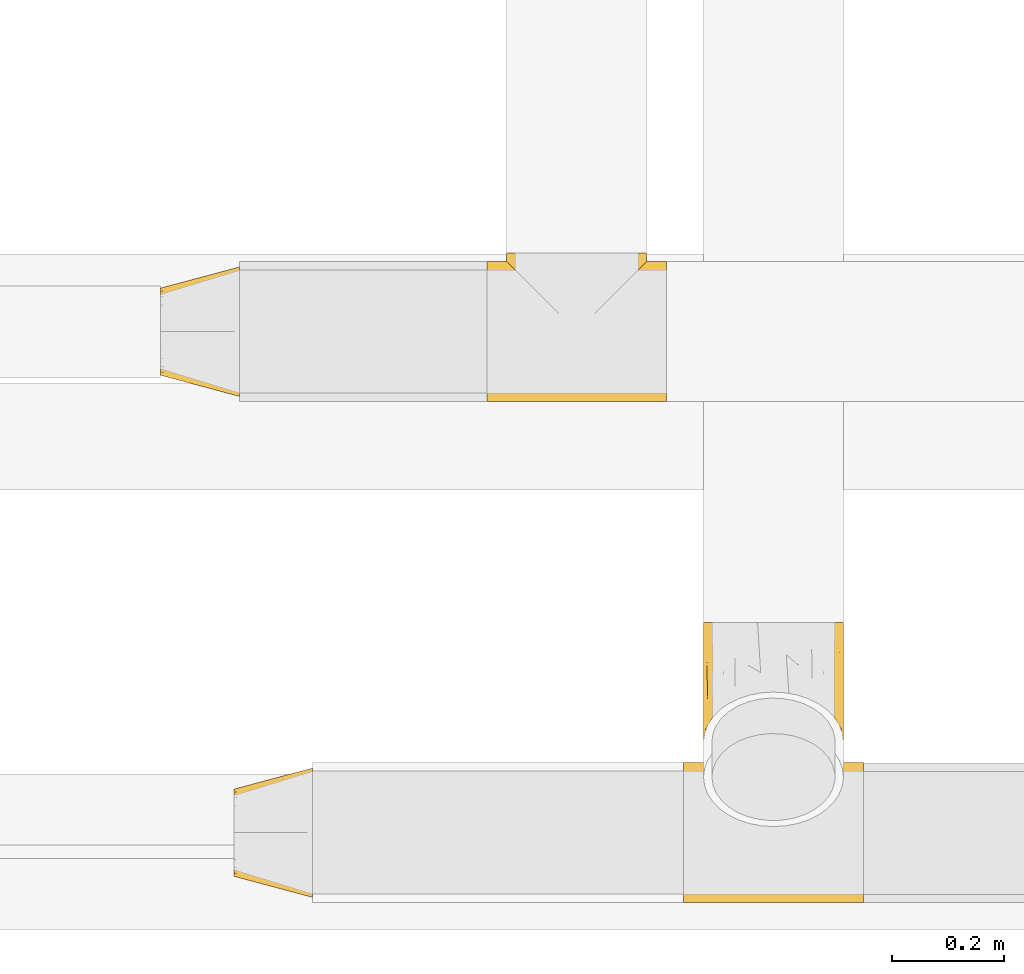
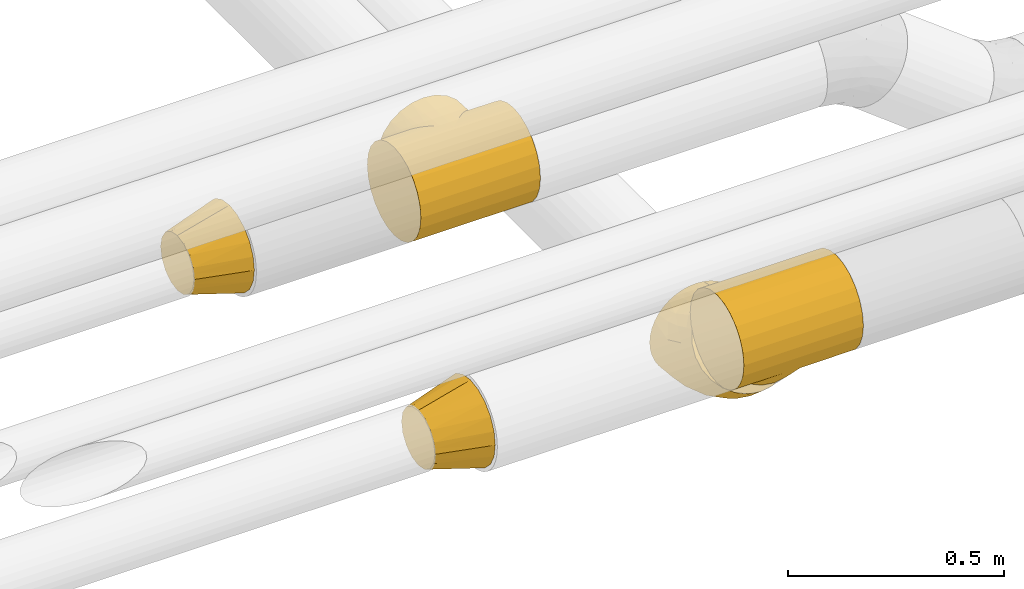
# One storey, part 139 of 827: 5 coverings.
"""IFC2X3 building model written with IfcOpenShell, lengths in millimetres."""

from ifc_helpers import new_model, entity, si_unit, converted_unit, derived_unit, direction, frame, origin, place, context, subcontext, project, spatial, faceted_brep, element, save


model = new_model("IFC2X3")

# Units and contexts
model_context = context("Model", 3, precision=0.01, world=origin(), true_north=direction((6.12303176911189e-17, 1.0)))
body_context = subcontext(model_context, "Body", "Model", "MODEL_VIEW")
ifc_project = project(units=[si_unit("LENGTHUNIT", "METRE", prefix="MILLI"), si_unit("AREAUNIT", "SQUARE_METRE"), si_unit("VOLUMEUNIT", "CUBIC_METRE"), converted_unit("PLANEANGLEUNIT", "DEGREE", entity("IfcRatioMeasure", 0.0174532925199433), si_unit("PLANEANGLEUNIT", "RADIAN"), dimensions=[0, 0, 0, 0, 0, 0, 0]), si_unit("MASSUNIT", "GRAM", prefix="KILO"), derived_unit("MASSDENSITYUNIT", [(si_unit("MASSUNIT", "GRAM", prefix="KILO"), 1), (si_unit("LENGTHUNIT", "METRE"), -3)]), derived_unit("MOMENTOFINERTIAUNIT", [(si_unit("LENGTHUNIT", "METRE"), 4)]), si_unit("TIMEUNIT", "SECOND"), si_unit("FREQUENCYUNIT", "HERTZ"), si_unit("THERMODYNAMICTEMPERATUREUNIT", "DEGREE_CELSIUS"), derived_unit("THERMALTRANSMITTANCEUNIT", [(si_unit("MASSUNIT", "GRAM", prefix="KILO"), 1), (si_unit("THERMODYNAMICTEMPERATUREUNIT", "KELVIN"), -1), (si_unit("TIMEUNIT", "SECOND"), -3)]), derived_unit("VOLUMETRICFLOWRATEUNIT", [(si_unit("LENGTHUNIT", "METRE"), 3), (si_unit("TIMEUNIT", "SECOND"), -1)]), derived_unit("MASSFLOWRATEUNIT", [(si_unit("MASSUNIT", "GRAM", prefix="KILO"), 1), (si_unit("TIMEUNIT", "SECOND"), -1)]), derived_unit("ROTATIONALFREQUENCYUNIT", [(si_unit("TIMEUNIT", "SECOND"), -1)]), si_unit("ELECTRICCURRENTUNIT", "AMPERE"), si_unit("ELECTRICVOLTAGEUNIT", "VOLT"), si_unit("POWERUNIT", "WATT"), si_unit("FORCEUNIT", "NEWTON", prefix="KILO"), si_unit("ILLUMINANCEUNIT", "LUX"), si_unit("LUMINOUSFLUXUNIT", "LUMEN"), si_unit("LUMINOUSINTENSITYUNIT", "CANDELA"), derived_unit("USERDEFINED", [(si_unit("MASSUNIT", "GRAM", prefix="KILO"), -1), (si_unit("LENGTHUNIT", "METRE"), -2), (si_unit("TIMEUNIT", "SECOND"), 3), (si_unit("LUMINOUSFLUXUNIT", "LUMEN"), 1)]), derived_unit("LINEARVELOCITYUNIT", [(si_unit("LENGTHUNIT", "METRE"), 1), (si_unit("TIMEUNIT", "SECOND"), -1)]), si_unit("PRESSUREUNIT", "PASCAL"), derived_unit("USERDEFINED", [(si_unit("LENGTHUNIT", "METRE"), -2), (si_unit("MASSUNIT", "GRAM", prefix="KILO"), 1), (si_unit("TIMEUNIT", "SECOND"), -2)]), derived_unit("LINEARFORCEUNIT", [(si_unit("MASSUNIT", "GRAM", prefix="KILO"), 1), (si_unit("LENGTHUNIT", "METRE"), 1), (si_unit("TIMEUNIT", "SECOND"), -2), (si_unit("LENGTHUNIT", "METRE"), -1)]), derived_unit("PLANARFORCEUNIT", [(si_unit("MASSUNIT", "GRAM", prefix="KILO"), 1), (si_unit("LENGTHUNIT", "METRE"), 1), (si_unit("TIMEUNIT", "SECOND"), -2), (si_unit("LENGTHUNIT", "METRE"), -2)])], contexts=[model_context])

# Site, building, storey
site_placement = place(None, origin())
site = spatial("IfcSite", under=ifc_project, at=site_placement, CompositionType="ELEMENT")
building_placement = place(site_placement, origin())
building = spatial("IfcBuilding", under=site, at=building_placement, CompositionType="ELEMENT")
storey_placement = place(building_placement, frame((0.0, 0.0, 28200.0)))
storey = spatial("IfcBuildingStorey", under=building, at=storey_placement, Name="08", CompositionType="ELEMENT", Elevation=28200.0)

# Coverings
covering_1_placement = place(storey_placement, frame((30920.0, 7140.11, 2673.9)))
element("IfcCovering", 1, at=covering_1_placement, inside=storey, Name=":ADSK_", ObjectType=":ADSK_", PredefinedType="INSULATION", context=body_context, shape_type="Brep", body=[
    faceted_brep([(182.35, 148.44, 248.58), (320.01, 126.1, 250.6), (320.01, 158.32, 246.35), (320.01, 188.35, 233.92), (235.54, 201.62, 225.07), (225.46, 191.55, 232.0), (320.01, 214.13, 214.13), (215.03, 181.12, 237.78), (171.2, 137.29, 250.09), (160.01, 126.1, 250.6), (148.81, 137.29, 250.1), (0.01, 126.1, 250.6), (204.32, 170.41, 242.44), (193.41, 159.5, 246.03), (320.0, 233.92, 188.35), (262.45, 228.54, 196.85), (320.0, 246.35, 158.32), (275.9, 241.99, 171.57), (320.0, 240.13, 173.33), (283.5, 249.59, 141.87), (320.0, 250.6, 126.1), (284.5, 250.6, 126.1), (36.51, 249.59, 141.88), (35.5, 250.6, 126.1), (0.0, 250.6, 126.1), (320.0, 248.47, 142.21), (269.77, 235.86, 184.84), (280.57, 246.66, 157.16), (254.18, 220.27, 207.53), (245.15, 211.24, 216.93), (320.0, 248.47, 109.98), (0.0, 248.47, 109.99), (274.7, 240.79, 77.67), (320.0, 240.13, 78.86), (320.0, 233.92, 63.85), (320.0, 246.35, 93.87), (283.35, 249.44, 109.2), (259.59, 225.68, 51.38), (320.0, 214.13, 38.06), (280.0, 246.09, 92.9), (267.79, 233.88, 63.79), (250.39, 216.48, 40.48), (240.41, 206.5, 31.04), (229.83, 195.92, 23.02), (320.0, 188.35, 18.28), (207.4, 173.49, 10.97), (320.0, 158.32, 5.84), (218.79, 184.88, 16.35), (183.93, 150.03, 3.92), (320.0, 126.1, 1.6), (195.76, 161.85, 6.84), (171.99, 138.09, 2.18), (160.0, 126.1, 1.6), (148.01, 138.09, 2.18), (0.0, 126.1, 1.6), (0.0, 18.28, 63.85), (0.0, 5.84, 93.88), (0.0, 1.6, 126.1), (0.0, 5.84, 158.33), (0.0, 18.28, 188.35), (0.01, 38.06, 214.14), (0.01, 63.85, 233.92), (0.01, 93.87, 246.36), (0.01, 158.32, 246.36), (0.01, 188.35, 233.92), (0.01, 214.13, 214.14), (0.0, 233.92, 188.35), (0.0, 240.13, 173.34), (0.0, 246.35, 158.33), (0.0, 248.47, 142.22), (0.0, 246.35, 93.88), (0.0, 240.13, 78.87), (0.0, 233.92, 63.85), (0.0, 214.13, 38.07), (0.0, 188.35, 18.28), (0.0, 158.32, 5.85), (0.0, 93.87, 5.85), (0.0, 63.85, 18.28), (0.0, 38.06, 38.07), (320.01, 93.87, 246.35), (320.01, 63.85, 233.92), (320.01, 38.06, 214.13), (320.0, 18.28, 188.35), (320.0, 5.84, 158.32), (320.0, 1.6, 126.1), (320.0, 5.84, 93.87), (320.0, 18.28, 63.85), (320.0, 38.06, 38.06), (320.0, 63.85, 18.28), (320.0, 93.87, 5.84), (126.6, 159.5, 246.04), (115.69, 170.41, 242.45), (137.66, 148.44, 248.58), (104.99, 181.12, 237.78), (94.55, 191.55, 232.01), (84.48, 201.62, 225.07), (65.83, 220.27, 207.54), (57.56, 228.54, 196.85), (74.86, 211.24, 216.93), (44.11, 241.99, 171.58), (39.44, 246.66, 157.17), (50.24, 235.86, 184.85), (45.31, 240.79, 77.68), (40.01, 246.09, 92.91), (60.41, 225.68, 51.39), (69.61, 216.48, 40.48), (52.22, 233.88, 63.79), (36.65, 249.44, 109.21), (79.59, 206.5, 31.05), (112.6, 173.49, 10.98), (124.24, 161.85, 6.85), (136.07, 150.03, 3.92), (90.18, 195.92, 23.02), (101.22, 184.88, 16.35), (160.01, 266.1, 250.6), (192.23, 266.1, 246.36), (222.26, 266.1, 233.92), (248.04, 266.1, 214.13), (257.93, 266.1, 201.24), (267.83, 266.1, 188.35), (274.04, 266.1, 173.33), (280.26, 266.1, 158.32), (282.38, 266.1, 142.21), (284.5, 266.1, 126.1), (282.38, 266.1, 109.98), (280.26, 266.1, 93.87), (274.04, 266.1, 78.86), (267.82, 266.1, 63.85), (257.93, 266.1, 50.95), (248.04, 266.1, 38.06), (222.25, 266.1, 18.28), (192.22, 266.1, 5.84), (160.0, 266.1, 1.6), (127.78, 266.1, 5.84), (97.75, 266.1, 18.28), (71.97, 266.1, 38.07), (62.07, 266.1, 50.96), (52.18, 266.1, 63.85), (45.96, 266.1, 78.87), (39.74, 266.1, 93.88), (37.62, 266.1, 109.99), (35.5, 266.1, 126.1), (37.62, 266.1, 142.21), (39.75, 266.1, 158.33), (45.97, 266.1, 173.34), (52.18, 266.1, 188.35), (62.08, 266.1, 201.24), (71.97, 266.1, 214.14), (97.76, 266.1, 233.92), (127.78, 266.1, 246.36), (160.01, 223.5, 250.6), (160.0, 223.5, 1.6)], [[[0, 1, 2]], [[3, 4, 5]], [[4, 3, 6]], [[2, 3, 7]], [[5, 7, 3]], [[8, 9, 1]], [[9, 10, 11]], [[0, 8, 1]], [[12, 13, 2]], [[7, 12, 2]], [[0, 2, 13]], [[14, 15, 6]], [[16, 17, 18]], [[19, 20, 21]], [[22, 23, 24]], [[20, 19, 25]], [[26, 18, 17]], [[27, 16, 25]], [[28, 29, 6]], [[15, 28, 6]], [[27, 25, 19]], [[26, 14, 18]], [[27, 17, 16]], [[15, 14, 26]], [[6, 29, 4]], [[21, 20, 30]], [[23, 31, 24]], [[32, 33, 34]], [[30, 35, 36]], [[37, 34, 38]], [[39, 33, 32]], [[39, 36, 35]], [[39, 35, 33]], [[37, 40, 34]], [[41, 37, 38]], [[32, 34, 40]], [[21, 30, 36]], [[38, 42, 41]], [[43, 42, 44]], [[45, 44, 46]], [[44, 47, 43]], [[42, 38, 44]], [[48, 46, 49]], [[45, 47, 44]], [[50, 45, 46]], [[51, 48, 49]], [[52, 51, 49]], [[53, 52, 54]], [[50, 46, 48]], [[55, 56, 57, 58, 59, 60, 61, 62, 11, 63, 64, 65, 66, 67, 68, 69, 24, 31, 70, 71, 72, 73, 74, 75, 54, 76, 77, 78]], [[1, 79, 80, 81, 82, 83, 84, 85, 86, 87, 88, 89, 49, 46, 44, 38, 34, 33, 35, 30, 20, 25, 16, 18, 14, 6, 3, 2]], [[59, 82, 81, 60]], [[57, 84, 83, 58]], [[58, 83, 82, 59]], [[61, 80, 79, 62]], [[1, 9, 11, 62, 79]], [[60, 81, 80, 61]], [[90, 91, 63]], [[92, 90, 63]], [[10, 92, 11]], [[92, 63, 11]], [[63, 91, 93]], [[63, 93, 64]], [[64, 94, 95]], [[94, 64, 93]], [[64, 95, 65]], [[96, 97, 65]], [[98, 96, 65]], [[99, 68, 67]], [[99, 100, 68]], [[99, 67, 101]], [[97, 101, 66]], [[67, 66, 101]], [[66, 65, 97]], [[22, 24, 69]], [[69, 68, 100]], [[69, 100, 22]], [[98, 65, 95]], [[102, 71, 103]], [[104, 105, 73]], [[106, 104, 72]], [[107, 70, 31]], [[102, 106, 72]], [[107, 31, 23]], [[102, 72, 71]], [[103, 70, 107]], [[71, 70, 103]], [[104, 73, 72]], [[105, 108, 73]], [[109, 110, 75]], [[111, 53, 54]], [[110, 111, 75]], [[108, 112, 74]], [[74, 112, 113]], [[108, 74, 73]], [[75, 74, 109]], [[75, 111, 54]], [[109, 74, 113]], [[52, 49, 89, 76, 54]], [[76, 89, 88, 77]], [[88, 87, 78, 77]], [[78, 87, 86, 55]], [[55, 86, 85, 56]], [[56, 85, 84, 57]], [[114, 115, 116, 117, 118, 119, 120, 121, 122, 123, 124, 125, 126, 127, 128, 129, 130, 131, 132, 133, 134, 135, 136, 137, 138, 139, 140, 141, 142, 143, 144, 145, 146, 147, 148, 149]], [[19, 21, 123]], [[120, 119, 26]], [[122, 121, 27]], [[118, 117, 28]], [[17, 121, 120]], [[19, 122, 27]], [[17, 27, 121]], [[15, 119, 118]], [[15, 26, 119]], [[15, 118, 28]], [[0, 150, 8]], [[120, 26, 17]], [[19, 123, 122]], [[117, 29, 28]], [[29, 117, 4]], [[5, 4, 116]], [[7, 116, 115]], [[116, 7, 5]], [[117, 116, 4]], [[115, 114, 150]], [[12, 7, 115]], [[13, 12, 115]], [[115, 150, 0]], [[9, 8, 150]], [[13, 115, 0]], [[150, 149, 92]], [[148, 95, 94]], [[95, 148, 147]], [[149, 148, 93]], [[94, 93, 148]], [[114, 149, 150]], [[10, 150, 92]], [[91, 90, 149]], [[93, 91, 149]], [[92, 149, 90]], [[145, 97, 146]], [[143, 99, 144]], [[22, 141, 23]], [[141, 22, 142]], [[96, 146, 97]], [[100, 143, 142]], [[96, 98, 147]], [[96, 147, 146]], [[10, 9, 150]], [[101, 144, 99]], [[101, 145, 144]], [[100, 99, 143]], [[100, 142, 22]], [[97, 145, 101]], [[147, 98, 95]], [[23, 141, 140]], [[102, 138, 137]], [[140, 139, 107]], [[136, 135, 105]], [[103, 138, 102]], [[103, 107, 139]], [[103, 139, 138]], [[106, 136, 104]], [[106, 137, 136]], [[104, 136, 105]], [[111, 151, 53]], [[102, 137, 106]], [[23, 140, 107]], [[135, 108, 105]], [[112, 108, 134]], [[109, 134, 133]], [[134, 113, 112]], [[108, 135, 134]], [[133, 132, 151]], [[109, 113, 134]], [[110, 109, 133]], [[133, 151, 111]], [[52, 53, 151]], [[110, 133, 111]], [[151, 131, 48]], [[130, 42, 43]], [[42, 130, 129]], [[131, 130, 45]], [[43, 47, 130]], [[132, 131, 151]], [[51, 151, 48]], [[45, 50, 131]], [[47, 45, 130]], [[48, 131, 50]], [[128, 127, 40]], [[124, 123, 21]], [[125, 39, 126]], [[21, 36, 124]], [[51, 52, 151]], [[41, 129, 128]], [[37, 128, 40]], [[36, 125, 124]], [[41, 128, 37]], [[32, 126, 39]], [[36, 39, 125]], [[32, 127, 126]], [[40, 127, 32]], [[129, 41, 42]]]),
])
covering_2_placement = place(storey_placement, frame((30339.76, 7149.61, 2683.41)))
element("IfcCovering", 2, at=covering_2_placement, inside=storey, Name=":ADSK_", ObjectType=":ADSK_", PredefinedType="INSULATION", context=body_context, shape_type="Brep", body=[
    faceted_brep([(0.0, 86.94, 188.2), (0.0, 101.77, 191.15), (0.0, 116.6, 194.1), (0.0, 131.42, 191.15), (0.0, 146.25, 188.2), (0.0, 158.82, 179.8), (0.0, 171.4, 171.4), (0.0, 179.8, 158.83), (0.0, 188.2, 146.25), (0.0, 191.15, 131.42), (0.0, 194.1, 116.6), (0.0, 191.15, 101.77), (0.0, 188.2, 86.94), (0.0, 179.8, 74.37), (0.0, 171.4, 61.79), (0.0, 158.82, 53.39), (0.0, 146.25, 44.99), (0.0, 131.42, 42.05), (0.0, 116.6, 39.1), (0.0, 101.77, 42.05), (0.0, 86.94, 44.99), (0.0, 74.37, 53.39), (0.0, 61.79, 61.79), (0.0, 53.39, 74.37), (0.0, 44.99, 86.94), (0.0, 42.04, 101.77), (0.0, 39.1, 116.6), (0.0, 42.04, 131.42), (0.0, 44.99, 146.25), (0.0, 53.39, 158.83), (0.0, 61.79, 171.4), (0.0, 74.37, 179.8), (140.0, 1.6, 116.6), (140.0, 7.22, 81.06), (140.0, 23.56, 49.0), (140.0, 49.0, 23.56), (140.0, 81.06, 7.22), (140.0, 116.6, 1.6), (140.0, 152.13, 7.22), (140.0, 184.19, 23.56), (140.0, 209.63, 49.0), (140.0, 225.97, 81.06), (140.0, 231.6, 116.6), (140.0, 225.97, 152.13), (140.0, 209.63, 184.19), (140.0, 184.19, 209.63), (140.0, 152.13, 225.97), (140.0, 116.6, 231.6), (140.0, 81.06, 225.97), (140.0, 49.0, 209.63), (140.0, 23.56, 184.19), (140.0, 7.22, 152.13)], [[[0, 1, 2, 3, 4, 5, 6, 7, 8, 9, 10, 11, 12, 13, 14, 15, 16, 17, 18, 19, 20, 21, 22, 23, 24, 25, 26, 27, 28, 29, 30, 31]], [[32, 33, 34, 35, 36, 37, 38, 39, 40, 41, 42, 43, 44, 45, 46, 47, 48, 49, 50, 51]], [[37, 17, 38]], [[16, 39, 38]], [[40, 14, 13, 12]], [[15, 14, 39, 16]], [[41, 12, 11]], [[10, 42, 11]], [[17, 37, 18]], [[40, 12, 41]], [[11, 42, 41]], [[17, 16, 38]], [[14, 40, 39]], [[32, 25, 33]], [[24, 34, 33]], [[35, 22, 21, 20]], [[23, 22, 34, 24]], [[36, 20, 19]], [[18, 37, 19]], [[25, 32, 26]], [[35, 20, 36]], [[19, 37, 36]], [[25, 24, 33]], [[22, 35, 34]], [[47, 1, 48]], [[0, 49, 48]], [[50, 30, 29, 28]], [[31, 30, 49, 0]], [[51, 28, 27]], [[26, 32, 27]], [[1, 47, 2]], [[50, 28, 51]], [[27, 32, 51]], [[1, 0, 48]], [[30, 50, 49]], [[42, 9, 43]], [[8, 44, 43]], [[45, 6, 5, 4]], [[7, 6, 44, 8]], [[46, 4, 3]], [[2, 47, 3]], [[9, 42, 10]], [[45, 4, 46]], [[3, 47, 46]], [[9, 8, 43]], [[6, 45, 44]]]),
])
covering_3_placement = place(storey_placement, frame((31270.0, 6248.9, 2611.37)))
element("IfcCovering", 3, at=covering_3_placement, inside=storey, Name=":ADSK_", ObjectType=":ADSK_", PredefinedType="INSULATION", context=body_context, shape_type="Brep", body=[
    faceted_brep([(182.35, 228.5, 259.43), (320.0, 214.13, 276.66), (320.0, 233.92, 250.88), (320.0, 246.35, 220.85), (235.53, 249.49, 205.2), (225.45, 247.26, 217.23), (320.0, 250.6, 188.63), (215.02, 243.97, 228.69), (171.2, 221.69, 268.39), (160.0, 214.13, 276.66), (148.8, 221.69, 268.39), (0.0, 214.13, 276.66), (204.31, 239.7, 239.56), (193.4, 234.52, 249.81), (320.0, 246.35, 156.4), (262.44, 248.56, 166.21), (320.0, 233.92, 126.38), (275.9, 240.2, 138.83), (320.0, 240.13, 141.39), (283.5, 224.57, 112.45), (320.0, 214.13, 100.59), (284.5, 214.13, 100.59), (36.5, 224.57, 112.45), (35.5, 214.13, 100.59), (0.0, 214.13, 100.59), (320.0, 224.02, 113.48), (269.77, 245.25, 152.54), (280.56, 233.31, 125.34), (254.17, 250.27, 179.62), (245.15, 250.53, 192.65), (320.0, 201.24, 90.7), (0.0, 201.24, 90.7), (274.7, 172.96, 73.28), (320.0, 173.33, 74.59), (320.0, 158.32, 68.37), (320.0, 188.35, 80.8), (283.35, 201.37, 89.46), (259.59, 143.68, 65.37), (320.0, 126.1, 64.13), (279.99, 187.47, 80.31), (267.79, 158.25, 68.35), (250.39, 129.47, 64.17), (240.41, 115.74, 64.56), (229.82, 102.58, 66.37), (320.0, 93.87, 68.37), (207.4, 78.21, 73.7), (320.0, 63.85, 80.8), (218.78, 90.06, 69.45), (183.93, 56.63, 85.31), (320.0, 38.06, 100.59), (195.76, 67.05, 79.02), (171.99, 46.95, 92.52), (160.0, 38.06, 100.59), (148.01, 46.95, 92.52), (0.0, 38.06, 100.59), (0.0, 5.84, 220.85), (0.0, 18.28, 250.88), (0.0, 38.06, 276.66), (0.0, 63.85, 296.45), (0.0, 93.87, 308.88), (0.0, 126.1, 313.13), (0.0, 158.32, 308.88), (0.0, 188.35, 296.45), (0.0, 233.92, 250.88), (0.0, 246.35, 220.85), (0.0, 250.6, 188.63), (0.0, 246.35, 156.4), (0.0, 240.13, 141.39), (0.0, 233.92, 126.38), (0.0, 224.02, 113.48), (0.0, 188.35, 80.8), (0.0, 173.33, 74.59), (0.0, 158.32, 68.37), (0.0, 126.1, 64.13), (0.0, 93.87, 68.37), (0.0, 63.85, 80.8), (0.0, 18.28, 126.38), (0.0, 5.84, 156.4), (0.0, 1.6, 188.63), (320.0, 188.35, 296.45), (320.0, 158.32, 308.88), (320.0, 126.1, 313.13), (320.0, 93.87, 308.88), (320.0, 63.85, 296.45), (320.0, 38.06, 276.66), (320.0, 18.28, 250.88), (320.0, 5.84, 220.85), (320.0, 1.6, 188.63), (320.0, 5.84, 156.4), (320.0, 18.28, 126.38), (126.6, 234.52, 249.81), (115.69, 239.7, 239.56), (137.65, 228.5, 259.43), (104.98, 243.97, 228.69), (94.55, 247.26, 217.23), (84.47, 249.49, 205.2), (65.83, 250.27, 179.62), (57.56, 248.56, 166.21), (74.85, 250.53, 192.65), (44.1, 240.2, 138.83), (39.44, 233.31, 125.34), (50.23, 245.25, 152.54), (45.3, 172.96, 73.28), (40.01, 187.47, 80.31), (60.41, 143.68, 65.37), (69.61, 129.47, 64.17), (52.21, 158.25, 68.35), (36.65, 201.37, 89.46), (79.59, 115.74, 64.56), (112.6, 78.21, 73.7), (124.24, 67.05, 79.02), (136.07, 56.63, 85.31), (90.18, 102.58, 66.37), (101.22, 90.06, 69.45), (248.03, 287.34, 151.88), (257.93, 278.22, 142.76), (267.82, 269.11, 133.65), (274.04, 258.49, 123.03), (280.26, 247.88, 112.42), (282.38, 236.48, 101.02), (284.5, 225.09, 89.63), (282.38, 213.7, 78.24), (280.26, 202.31, 66.84), (274.04, 191.69, 56.23), (267.82, 181.07, 45.61), (257.93, 171.96, 36.5), (248.03, 162.84, 27.38), (222.25, 148.85, 13.39), (192.22, 140.06, 4.59), (160.0, 137.06, 1.6), (127.78, 140.06, 4.59), (97.75, 148.85, 13.39), (71.97, 162.84, 27.38), (62.07, 171.96, 36.5), (52.18, 181.07, 45.61), (45.96, 191.69, 56.23), (39.74, 202.31, 66.84), (37.62, 213.7, 78.24), (35.5, 225.09, 89.63), (37.62, 236.48, 101.02), (39.74, 247.88, 112.42), (45.96, 258.49, 123.03), (52.18, 269.11, 133.65), (62.07, 278.22, 142.76), (71.97, 287.34, 151.88), (97.75, 301.33, 165.87), (127.78, 310.13, 174.67), (160.0, 313.13, 177.66), (192.22, 310.13, 174.67), (222.25, 301.33, 165.87), (160.0, 283.0, 207.79), (160.0, 106.93, 31.72)], [[[0, 1, 2]], [[3, 4, 5]], [[4, 3, 6]], [[2, 3, 7]], [[5, 7, 3]], [[8, 9, 1]], [[9, 10, 11]], [[0, 8, 1]], [[12, 13, 2]], [[7, 12, 2]], [[0, 2, 13]], [[14, 15, 6]], [[16, 17, 18]], [[19, 20, 21]], [[22, 23, 24]], [[20, 19, 25]], [[26, 18, 17]], [[27, 16, 25]], [[28, 29, 6]], [[15, 28, 6]], [[27, 25, 19]], [[26, 14, 18]], [[27, 17, 16]], [[15, 14, 26]], [[6, 29, 4]], [[21, 20, 30]], [[23, 31, 24]], [[32, 33, 34]], [[30, 35, 36]], [[37, 34, 38]], [[39, 33, 32]], [[39, 36, 35]], [[39, 35, 33]], [[37, 40, 34]], [[41, 37, 38]], [[32, 34, 40]], [[21, 30, 36]], [[38, 42, 41]], [[43, 42, 44]], [[45, 44, 46]], [[44, 47, 43]], [[42, 38, 44]], [[48, 46, 49]], [[45, 47, 44]], [[50, 45, 46]], [[51, 48, 49]], [[52, 51, 49]], [[53, 52, 54]], [[50, 46, 48]], [[55, 56, 57, 58, 59, 60, 61, 62, 11, 63, 64, 65, 66, 67, 68, 69, 24, 31, 70, 71, 72, 73, 74, 75, 54, 76, 77, 78]], [[1, 79, 80, 81, 82, 83, 84, 85, 86, 87, 88, 89, 49, 46, 44, 38, 34, 33, 35, 30, 20, 25, 16, 18, 14, 6, 3, 2]], [[58, 83, 82, 59]], [[59, 82, 81, 60]], [[84, 83, 58, 57]], [[61, 80, 79, 62]], [[1, 9, 11, 62, 79]], [[60, 81, 80, 61]], [[90, 91, 63]], [[92, 90, 63]], [[10, 92, 11]], [[92, 63, 11]], [[63, 91, 93]], [[63, 93, 64]], [[64, 94, 95]], [[94, 64, 93]], [[64, 95, 65]], [[96, 97, 65]], [[98, 96, 65]], [[99, 68, 67]], [[99, 100, 68]], [[99, 67, 101]], [[97, 101, 66]], [[67, 66, 101]], [[66, 65, 97]], [[22, 24, 69]], [[69, 68, 100]], [[69, 100, 22]], [[98, 65, 95]], [[102, 71, 103]], [[104, 105, 73]], [[106, 104, 72]], [[107, 70, 31]], [[102, 106, 72]], [[107, 31, 23]], [[102, 72, 71]], [[103, 70, 107]], [[71, 70, 103]], [[104, 73, 72]], [[105, 108, 73]], [[109, 110, 75]], [[111, 53, 54]], [[110, 111, 75]], [[108, 112, 74]], [[74, 112, 113]], [[108, 74, 73]], [[75, 74, 109]], [[75, 111, 54]], [[109, 74, 113]], [[52, 49, 89, 76, 54]], [[76, 89, 88, 77]], [[88, 87, 78, 77]], [[78, 87, 86, 55]], [[55, 86, 85, 56]], [[56, 85, 84, 57]], [[114, 115, 116, 117, 118, 119, 120, 121, 122, 123, 124, 125, 126, 127, 128, 129, 130, 131, 132, 133, 134, 135, 136, 137, 138, 139, 140, 141, 142, 143, 144, 145, 146, 147, 148, 149]], [[19, 21, 120]], [[117, 116, 26]], [[119, 118, 27]], [[115, 114, 28]], [[17, 118, 117]], [[19, 119, 27]], [[17, 27, 118]], [[15, 116, 115]], [[15, 26, 116]], [[15, 115, 28]], [[0, 150, 8]], [[117, 26, 17]], [[19, 120, 119]], [[114, 29, 28]], [[29, 114, 4]], [[5, 4, 149]], [[7, 149, 148]], [[149, 7, 5]], [[114, 149, 4]], [[148, 147, 150]], [[12, 7, 148]], [[13, 12, 148]], [[148, 150, 0]], [[9, 8, 150]], [[13, 148, 0]], [[150, 146, 92]], [[145, 95, 94]], [[95, 145, 144]], [[146, 145, 93]], [[94, 93, 145]], [[147, 146, 150]], [[10, 150, 92]], [[91, 90, 146]], [[93, 91, 146]], [[92, 146, 90]], [[142, 97, 143]], [[140, 99, 141]], [[22, 138, 23]], [[138, 22, 139]], [[96, 143, 97]], [[100, 140, 139]], [[96, 98, 144]], [[96, 144, 143]], [[10, 9, 150]], [[101, 141, 99]], [[101, 142, 141]], [[100, 99, 140]], [[100, 139, 22]], [[97, 142, 101]], [[144, 98, 95]], [[23, 138, 137]], [[102, 135, 134]], [[137, 136, 107]], [[133, 132, 105]], [[103, 135, 102]], [[103, 107, 136]], [[103, 136, 135]], [[106, 133, 104]], [[106, 134, 133]], [[104, 133, 105]], [[111, 151, 53]], [[102, 134, 106]], [[23, 137, 107]], [[132, 108, 105]], [[112, 108, 131]], [[109, 131, 130]], [[131, 113, 112]], [[108, 132, 131]], [[130, 129, 151]], [[109, 113, 131]], [[110, 109, 130]], [[130, 151, 111]], [[52, 53, 151]], [[110, 130, 111]], [[151, 128, 48]], [[127, 42, 43]], [[42, 127, 126]], [[128, 127, 45]], [[43, 47, 127]], [[129, 128, 151]], [[51, 151, 48]], [[45, 50, 128]], [[47, 45, 127]], [[48, 128, 50]], [[125, 124, 40]], [[121, 120, 21]], [[122, 39, 123]], [[21, 36, 121]], [[51, 52, 151]], [[41, 126, 125]], [[37, 125, 40]], [[36, 122, 121]], [[41, 125, 37]], [[32, 123, 39]], [[36, 39, 122]], [[32, 124, 123]], [[40, 124, 32]], [[126, 41, 42]]]),
])
covering_4_placement = place(storey_placement, frame((30470.11, 6258.4, 2683.4)))
element("IfcCovering", 4, at=covering_4_placement, inside=storey, Name=":ADSK_", ObjectType=":ADSK_", PredefinedType="INSULATION", context=body_context, shape_type="Brep", body=[
    faceted_brep([(0.0, 86.94, 188.2), (0.0, 101.77, 191.15), (0.0, 116.6, 194.1), (0.0, 131.42, 191.15), (0.0, 146.25, 188.2), (0.0, 158.82, 179.8), (0.0, 171.4, 171.4), (0.0, 179.8, 158.82), (0.0, 188.2, 146.25), (0.0, 191.15, 131.42), (0.0, 194.1, 116.6), (0.0, 191.15, 101.77), (0.0, 188.2, 86.94), (0.0, 179.8, 74.37), (0.0, 171.4, 61.79), (0.0, 158.82, 53.39), (0.0, 146.25, 44.99), (0.0, 131.42, 42.04), (0.0, 116.6, 39.1), (0.0, 101.77, 42.04), (0.0, 86.94, 44.99), (0.0, 74.37, 53.39), (0.0, 61.79, 61.79), (0.0, 53.39, 74.37), (0.0, 44.99, 86.94), (0.0, 42.04, 101.77), (0.0, 39.1, 116.6), (0.0, 42.04, 131.42), (0.0, 44.99, 146.25), (0.0, 53.39, 158.82), (0.0, 61.79, 171.4), (0.0, 74.37, 179.8), (140.0, 81.06, 7.22), (140.0, 116.6, 1.6), (140.0, 152.13, 7.22), (140.0, 184.19, 23.56), (140.0, 209.63, 49.0), (140.0, 225.97, 81.06), (140.0, 231.6, 116.6), (140.0, 225.97, 152.13), (140.0, 209.63, 184.19), (140.0, 184.19, 209.63), (140.0, 152.13, 225.97), (140.0, 116.6, 231.6), (140.0, 81.06, 225.97), (140.0, 49.0, 209.63), (140.0, 23.56, 184.19), (140.0, 7.22, 152.13), (140.0, 1.6, 116.6), (140.0, 7.22, 81.06), (140.0, 23.56, 49.0), (140.0, 49.0, 23.56)], [[[0, 1, 2, 3, 4, 5, 6, 7, 8, 9, 10, 11, 12, 13, 14, 15, 16, 17, 18, 19, 20, 21, 22, 23, 24, 25, 26, 27, 28, 29, 30, 31]], [[32, 33, 34, 35, 36, 37, 38, 39, 40, 41, 42, 43, 44, 45, 46, 47, 48, 49, 50, 51]], [[33, 17, 34]], [[16, 35, 34]], [[36, 14, 13, 12]], [[15, 14, 35, 16]], [[37, 12, 11]], [[10, 38, 11]], [[17, 33, 18]], [[36, 12, 37]], [[11, 38, 37]], [[17, 16, 34]], [[14, 36, 35]], [[48, 25, 49]], [[24, 50, 49]], [[51, 22, 21, 20]], [[23, 22, 50, 24]], [[32, 20, 19]], [[18, 33, 19]], [[25, 48, 26]], [[51, 20, 32]], [[19, 33, 32]], [[25, 24, 49]], [[22, 51, 50]], [[43, 1, 44]], [[0, 45, 44]], [[46, 30, 29, 28]], [[31, 30, 45, 0]], [[47, 28, 27]], [[26, 48, 27]], [[1, 43, 2]], [[46, 28, 47]], [[27, 48, 47]], [[1, 0, 44]], [[30, 46, 45]], [[38, 9, 39]], [[8, 40, 39]], [[41, 6, 5, 4]], [[7, 6, 40, 8]], [[42, 4, 3]], [[2, 43, 3]], [[9, 38, 10]], [[41, 4, 42]], [[3, 43, 42]], [[9, 8, 39]], [[6, 41, 40]]]),
])
covering_5_placement = place(storey_placement, frame((31303.9, 6447.5, 2423.9)))
element("IfcCovering", 5, at=covering_5_placement, inside=storey, Name=":ADSK_", ObjectType=":ADSK_", PredefinedType="INSULATION", context=body_context, shape_type="Brep", body=[
    faceted_brep([(182.62, 301.76, 237.02), (199.28, 301.76, 226.82), (214.13, 301.76, 214.13), (226.82, 301.76, 199.27), (237.03, 301.76, 182.61), (244.5, 301.76, 164.56), (249.06, 301.76, 145.56), (250.6, 301.76, 126.1), (249.06, 301.76, 106.62), (244.5, 301.76, 87.62), (237.02, 301.76, 69.57), (226.82, 301.76, 52.91), (214.13, 301.76, 38.06), (199.27, 301.76, 25.37), (182.61, 301.76, 15.16), (164.56, 301.76, 7.69), (145.56, 301.76, 3.13), (126.1, 301.76, 1.6), (106.62, 301.76, 3.13), (87.62, 301.76, 7.69), (69.57, 301.76, 15.17), (52.91, 301.76, 25.37), (38.06, 301.76, 38.06), (25.37, 301.76, 52.92), (15.16, 301.76, 69.58), (7.69, 301.76, 87.63), (3.13, 301.76, 106.63), (1.6, 301.76, 126.1), (3.13, 301.76, 145.57), (7.69, 301.76, 164.57), (15.17, 301.76, 182.62), (25.37, 301.76, 199.28), (38.06, 301.76, 214.13), (52.92, 301.76, 226.82), (69.58, 301.76, 237.03), (87.63, 301.76, 244.5), (106.63, 301.76, 249.06), (126.1, 301.76, 250.6), (145.57, 301.76, 249.06), (164.57, 301.76, 244.5), (93.87, 174.67, 299.0), (63.85, 165.87, 290.2), (38.06, 151.88, 276.21), (18.28, 133.65, 257.98), (5.84, 112.42, 236.75), (1.6, 89.63, 213.96), (5.84, 66.84, 191.18), (18.28, 45.61, 169.95), (38.06, 27.38, 151.71), (63.85, 13.39, 137.72), (93.87, 4.59, 128.93), (126.1, 1.6, 125.93), (158.32, 4.59, 128.93), (188.35, 13.39, 137.72), (214.13, 27.38, 151.71), (233.92, 45.61, 169.95), (246.35, 66.84, 191.18), (250.6, 89.63, 213.96), (246.35, 112.42, 236.75), (233.92, 133.65, 257.98), (214.13, 151.88, 276.21), (188.35, 165.87, 290.2), (158.32, 174.67, 299.0), (126.1, 177.66, 302.0), (149.06, 75.83, 69.24), (157.57, 140.86, 37.65), (172.62, 70.72, 80.78), (126.1, 52.25, 82.67), (172.54, 216.09, 19.51), (205.38, 214.85, 39.76), (228.86, 231.05, 62.63), (211.39, 133.57, 73.47), (126.1, 170.58, 22.37), (126.1, 109.04, 47.86), (126.1, 235.36, 6.82), (148.92, 208.76, 14.07), (196.14, 79.22, 90.2), (188.53, 146.9, 48.93), (241.93, 143.62, 118.76), (239.97, 221.63, 85.05), (247.93, 204.61, 115.3), (224.58, 89.85, 115.31), (229.78, 161.88, 84.73), (248.4, 138.51, 147.07), (250.6, 186.96, 148.93), (250.6, 135.09, 176.65), (250.6, 243.24, 131.86), (243.25, 158.77, 211.5), (247.16, 201.06, 174.55), (237.03, 209.27, 200.86), (219.17, 198.2, 235.05), (232.82, 176.23, 226.38), (175.8, 258.24, 245.41), (148.67, 233.81, 262.05), (170.51, 211.15, 266.31), (243.33, 249.02, 173.44), (189.91, 195.55, 264.83), (195.3, 227.35, 244.22), (195.29, 264.76, 233.11), (126.1, 214.01, 274.11), (223.78, 249.97, 209.38), (126.1, 256.34, 256.58), (99.35, 246.87, 256.34), (94.07, 208.34, 272.6), (8.49, 167.71, 204.31), (1.6, 186.96, 148.93), (1.6, 135.09, 176.65), (25.02, 171.95, 239.5), (26.42, 215.51, 217.85), (48.04, 201.86, 249.38), (42.36, 252.95, 224.04), (74.96, 228.83, 254.46), (76.79, 266.4, 243.81), (73.49, 194.49, 272.73), (8.09, 229.26, 176.09), (25.62, 257.61, 203.96), (1.6, 243.24, 131.86), (10.26, 143.63, 118.76), (27.6, 89.87, 115.31), (40.79, 133.57, 73.47), (56.04, 79.2, 90.22), (3.79, 138.52, 147.07), (4.26, 204.61, 115.3), (103.13, 75.83, 69.24), (46.81, 214.85, 39.76), (63.66, 146.9, 48.94), (79.57, 70.71, 80.78), (94.61, 140.86, 37.65), (22.4, 161.89, 84.73), (103.26, 208.77, 14.07), (79.64, 216.09, 19.51), (23.32, 231.05, 62.64), (12.22, 221.63, 85.06)], [[[0, 1, 2, 3, 4, 5, 6, 7, 8, 9, 10, 11, 12, 13, 14, 15, 16, 17, 18, 19, 20, 21, 22, 23, 24, 25, 26, 27, 28, 29, 30, 31, 32, 33, 34, 35, 36, 37, 38, 39]], [[40, 41, 42, 43, 44, 45, 46, 47, 48, 49, 50, 51, 52, 53, 54, 55, 56, 57, 58, 59, 60, 61, 62, 63]], [[64, 65, 66]], [[67, 52, 51]], [[68, 14, 13]], [[69, 70, 71]], [[72, 65, 73]], [[72, 74, 75]], [[13, 12, 69]], [[64, 73, 65]], [[70, 12, 11]], [[76, 66, 77]], [[78, 79, 80]], [[55, 81, 78]], [[78, 82, 79]], [[80, 9, 8]], [[76, 77, 71]], [[57, 56, 83]], [[78, 80, 83]], [[68, 69, 77]], [[77, 69, 71]], [[84, 85, 83]], [[14, 68, 15]], [[77, 65, 68]], [[69, 68, 13]], [[75, 68, 65]], [[78, 81, 82]], [[70, 69, 12]], [[68, 75, 15]], [[16, 74, 17]], [[53, 66, 76]], [[76, 71, 81]], [[54, 76, 81]], [[54, 81, 55]], [[86, 8, 7]], [[84, 80, 86]], [[80, 84, 83]], [[53, 52, 66]], [[64, 52, 67]], [[82, 70, 79]], [[81, 71, 82]], [[86, 80, 8]], [[76, 54, 53]], [[79, 10, 9]], [[10, 79, 70]], [[55, 78, 56]], [[77, 66, 65]], [[75, 16, 15]], [[72, 75, 65]], [[80, 79, 9]], [[16, 75, 74]], [[70, 82, 71]], [[10, 70, 11]], [[57, 83, 85]], [[56, 78, 83]], [[52, 64, 66]], [[73, 64, 67]], [[58, 85, 87]], [[58, 57, 85]], [[87, 85, 88]], [[89, 90, 91]], [[91, 60, 59]], [[91, 87, 89]], [[92, 93, 94]], [[38, 93, 92]], [[88, 95, 89]], [[96, 97, 94]], [[94, 97, 92]], [[98, 2, 1]], [[88, 85, 84]], [[99, 63, 62]], [[93, 62, 94]], [[61, 94, 62]], [[98, 0, 92]], [[38, 92, 39]], [[100, 4, 3]], [[87, 88, 89]], [[3, 2, 100]], [[100, 95, 4]], [[6, 95, 86]], [[98, 100, 2]], [[90, 97, 96]], [[5, 95, 6]], [[7, 6, 86]], [[93, 101, 99]], [[0, 98, 1]], [[62, 93, 99]], [[59, 58, 87]], [[37, 101, 38]], [[93, 38, 101]], [[86, 95, 88]], [[100, 90, 89]], [[0, 39, 92]], [[95, 100, 89]], [[90, 96, 60]], [[92, 97, 98]], [[90, 100, 97]], [[100, 98, 97]], [[5, 4, 95]], [[94, 61, 96]], [[86, 88, 84]], [[96, 61, 60]], [[60, 91, 90]], [[59, 87, 91]], [[102, 103, 99]], [[104, 105, 106]], [[102, 99, 101]], [[104, 107, 108]], [[109, 107, 42]], [[103, 63, 99]], [[110, 111, 112]], [[109, 111, 110]], [[36, 102, 101]], [[113, 103, 111]], [[114, 104, 108]], [[45, 44, 106]], [[104, 44, 43]], [[41, 109, 42]], [[109, 108, 107]], [[106, 44, 104]], [[104, 43, 107]], [[104, 114, 105]], [[36, 35, 102]], [[30, 115, 31]], [[115, 30, 114]], [[43, 42, 107]], [[34, 112, 35]], [[35, 112, 102]], [[33, 110, 112]], [[113, 40, 103]], [[115, 110, 32]], [[31, 115, 32]], [[116, 114, 29]], [[33, 32, 110]], [[110, 115, 108]], [[114, 30, 29]], [[109, 110, 108]], [[114, 116, 105]], [[112, 111, 102]], [[102, 111, 103]], [[28, 27, 116]], [[29, 28, 116]], [[113, 109, 41]], [[112, 34, 33]], [[109, 113, 111]], [[36, 101, 37]], [[40, 113, 41]], [[103, 40, 63]], [[114, 108, 115]], [[117, 47, 46]], [[117, 118, 47]], [[118, 119, 120]], [[121, 122, 117]], [[73, 67, 123]], [[119, 124, 125]], [[122, 121, 105]], [[106, 121, 45]], [[123, 126, 127]], [[118, 128, 119]], [[67, 51, 50]], [[129, 130, 19]], [[48, 120, 49]], [[125, 127, 126]], [[50, 126, 123]], [[73, 127, 72]], [[19, 18, 129]], [[131, 119, 128]], [[126, 50, 49]], [[130, 20, 19]], [[24, 132, 25]], [[126, 49, 120]], [[116, 27, 26]], [[131, 22, 124]], [[118, 48, 47]], [[132, 122, 25]], [[132, 131, 128]], [[121, 106, 105]], [[117, 128, 118]], [[131, 24, 23]], [[125, 126, 120]], [[124, 22, 21]], [[124, 21, 130]], [[130, 21, 20]], [[26, 122, 116]], [[129, 18, 74]], [[127, 130, 129]], [[132, 117, 122]], [[17, 74, 18]], [[127, 125, 130]], [[124, 130, 125]], [[127, 129, 72]], [[122, 105, 116]], [[48, 118, 120]], [[132, 128, 117]], [[25, 122, 26]], [[120, 119, 125]], [[119, 131, 124]], [[72, 129, 74]], [[24, 131, 132]], [[131, 23, 22]], [[117, 46, 121]], [[45, 121, 46]], [[73, 123, 127]], [[50, 123, 67]]]),
])

save(model, "model.ifc")
